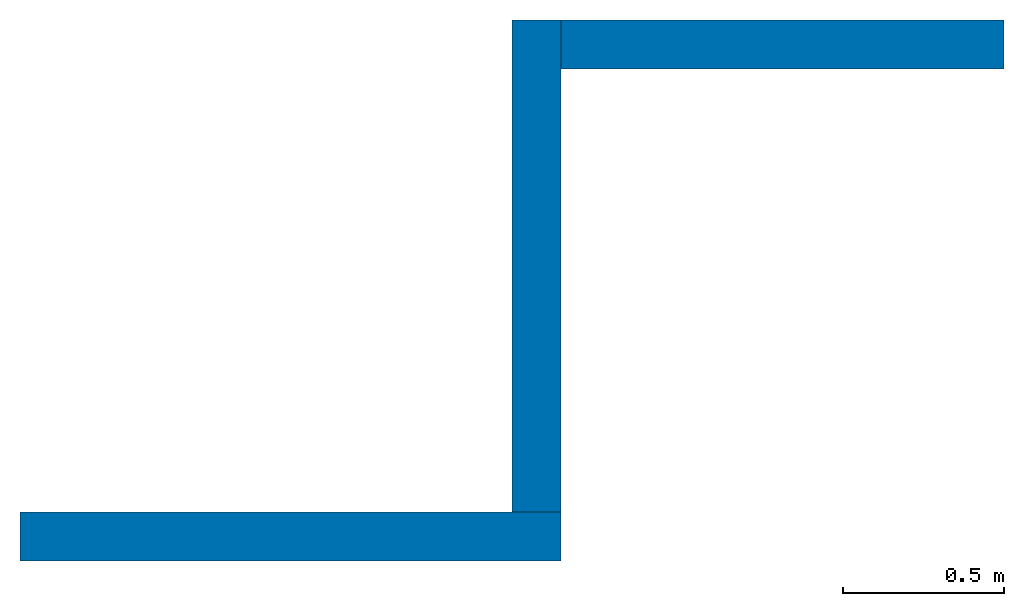
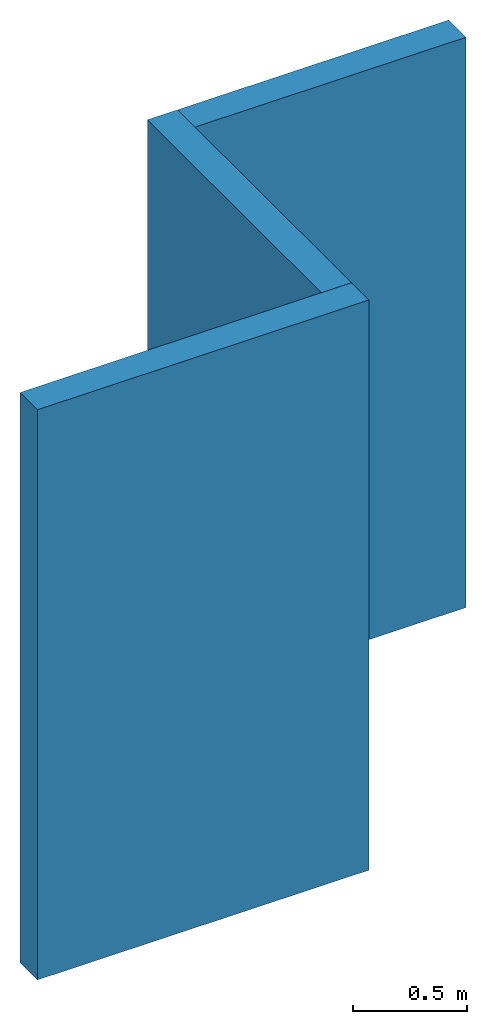
# One storey: 3 walls.
"""IFC2X3 building model written with IfcOpenShell, lengths in feet."""

import ifcopenshell
import ifcopenshell.guid

model = None  # the IFC model being written
_history = None  # IfcOwnerHistory: only IFC2X3 demands one
_inside = {}  # id of a spatial element -> (the spatial element, [elements in it])
_under = {}  # id of a project, library or spatial element -> (it, [spatial elements below it])
_declared = {}  # id of a project -> (the project, [libraries it declares])
_typed = {}  # id of a type object -> (the type object, [elements of that type])
_made_of = {}  # id of a material, layer set ... -> (it, [elements and type objects made of it])


def new_model(schema):
    """Start an empty IFC model of exactly this schema.

    Asked for "IFC4X3", IfcOpenShell would pick the latest addendum, in which some entities
    have other attributes; the version numbers below select the first issue.
    IFC2X3 requires an IfcOwnerHistory on every rooted entity: one is made here for all.
    """
    global model, _history
    if schema == "IFC4X3":
        model = ifcopenshell.file(schema_version=(4, 3, 0, 0))
    else:
        model = ifcopenshell.file(schema=schema)
    _inside.clear()
    _under.clear()
    _declared.clear()
    _typed.clear()
    _made_of.clear()
    _history = None
    if model.schema == "IFC2X3":
        org = make("IfcOrganization", Name="unknown")
        user = make(
            "IfcPersonAndOrganization",
            ThePerson=make("IfcPerson", FamilyName="unknown"),
            TheOrganization=org,
        )
        app = make(
            "IfcApplication",
            ApplicationDeveloper=org,
            Version="unknown",
            ApplicationFullName="unknown",
            ApplicationIdentifier="unknown",
        )
        _history = make(
            "IfcOwnerHistory",
            OwningUser=user,
            OwningApplication=app,
            ChangeAction="ADDED",
            CreationDate=0,
        )
    return model


def make(cls, **values):
    """One entity of the class cls with the attributes given. An attribute that is None is left unset."""
    return model.create_entity(
        cls, **{name: value for name, value in values.items() if value is not None}
    )


def entity(cls, *values):
    """Any entity or typed value of the class cls, its attributes in the order of the schema. None: left unset."""
    e = model.create_entity(cls)
    for i, value in enumerate(values):
        if value is not None:
            e[i] = value
    return e


def rooted(cls, **values):
    """An entity with a GlobalId (a new one), such as an element, a storey or a relation."""
    return make(cls, GlobalId=ifcopenshell.guid.new(), OwnerHistory=_history, **values)


def si_unit(unit_type, name, prefix=None):
    """IfcSIUnit, for example si_unit("LENGTHUNIT", "METRE", prefix="MILLI")."""
    return make("IfcSIUnit", UnitType=unit_type, Prefix=prefix, Name=name)


def converted_unit(unit_type, name, factor, base, dimensions=None, offset=None):
    """IfcConversionBasedUnit, such as the inch: factor (a typed value) times the base unit."""
    return make(
        "IfcConversionBasedUnit"
        if offset is None
        else "IfcConversionBasedUnitWithOffset",
        ConversionOffset=offset,
        Dimensions=None
        if dimensions is None
        else entity("IfcDimensionalExponents", *dimensions),
        UnitType=unit_type,
        Name=name,
        ConversionFactor=make(
            "IfcMeasureWithUnit", ValueComponent=factor, UnitComponent=base
        ),
    )


def derived_unit(unit_type, elements):
    """IfcDerivedUnit: a product of units, each with its exponent."""
    return make(
        "IfcDerivedUnit",
        Elements=[
            make("IfcDerivedUnitElement", Unit=unit, Exponent=power)
            for unit, power in elements
        ],
        UnitType=unit_type,
    )


def assignment(units):
    """IfcUnitAssignment: the units of a project."""
    return None if units is None else make("IfcUnitAssignment", Units=units)


def point(xyz):
    """IfcCartesianPoint."""
    return None if xyz is None else make("IfcCartesianPoint", Coordinates=xyz)


def direction(xyz):
    """IfcDirection."""
    return None if xyz is None else make("IfcDirection", DirectionRatios=xyz)


def frame(location, z_axis=None, x_axis=None):
    """IfcAxis2Placement3D, a coordinate frame: its origin and axes. An axis left out is left unset."""
    return make(
        "IfcAxis2Placement3D",
        Location=point(location),
        Axis=direction(z_axis),
        RefDirection=direction(x_axis),
    )


def frame_2d(location, x_axis=None):
    """IfcAxis2Placement2D, a coordinate frame in the plane: its origin and x axis."""
    return make(
        "IfcAxis2Placement2D", Location=point(location), RefDirection=direction(x_axis)
    )


def origin():
    """The frame at (0, 0, 0) with its axes left unset."""
    return frame((0.0, 0.0, 0.0))


def place(relative_to, where):
    """IfcLocalPlacement: puts the frame where relative to a parent placement (None: the world)."""
    return make(
        "IfcLocalPlacement", PlacementRelTo=relative_to, RelativePlacement=where
    )


def context(
    kind, dimensions, precision=None, world=None, true_north=None, identifier=None
):
    """IfcGeometricRepresentationContext, for example the 3D "Model" context."""
    return make(
        "IfcGeometricRepresentationContext",
        ContextIdentifier=identifier,
        ContextType=kind,
        CoordinateSpaceDimension=dimensions,
        Precision=precision,
        WorldCoordinateSystem=world,
        TrueNorth=true_north,
    )


def subcontext(parent, identifier, kind, view, scale=None):
    """IfcGeometricRepresentationSubContext, for example "Body" below "Model"."""
    return make(
        "IfcGeometricRepresentationSubContext",
        ContextIdentifier=identifier,
        ContextType=kind,
        ParentContext=parent,
        TargetScale=scale,
        TargetView=view,
    )


def project(units=None, contexts=None):
    """IfcProject with its units and contexts."""
    return rooted(
        "IfcProject",
        Name="project",
        RepresentationContexts=contexts,
        UnitsInContext=assignment(units),
    )


def spatial(cls, under=None, at=None, **own):
    """A site, building, storey or space (cls), placed at a placement, below another one or the project."""
    s = rooted(cls, ObjectPlacement=at, **own)
    if under is not None:
        _under.setdefault(under.id(), (under, []))[1].append(s)
    return s


def profile(cls, at=None, kind="AREA", **sizes):
    """A parametric profile (cls). Its sizes go by their IFC names, for example OverallWidth=200.0."""
    return make(cls, ProfileType=kind, Position=at, **sizes)


def rectangle(**sizes):
    """IfcRectangleProfileDef."""
    return profile("IfcRectangleProfileDef", **sizes)


def extrude(swept, where, along, depth):
    """IfcExtrudedAreaSolid: the profile swept, set in the frame where, extruded along a direction by depth."""
    return make(
        "IfcExtrudedAreaSolid",
        SweptArea=swept,
        Position=where,
        ExtrudedDirection=direction(along),
        Depth=depth,
    )


def shape(context_of_items, identifier, shape_type, items):
    """IfcShapeRepresentation: the items that make up one representation, for example the "Body"."""
    return make(
        "IfcShapeRepresentation",
        ContextOfItems=context_of_items,
        RepresentationIdentifier=identifier,
        RepresentationType=shape_type,
        Items=items,
    )


def material(Name=None, Category=None):
    """IfcMaterial."""
    return make("IfcMaterial", Name=Name, Category=Category)


def layer(
    of_material, thickness, ventilated=None, Name=None, Category=None, Priority=None
):
    """IfcMaterialLayer: one layer of a wall or slab, of a material (None: an air gap)."""
    return make(
        "IfcMaterialLayer",
        Material=of_material,
        LayerThickness=thickness,
        IsVentilated=ventilated,
        Name=Name,
        Category=Category,
        Priority=Priority,
    )


def layer_set(layers, Name=None):
    """IfcMaterialLayerSet."""
    return make("IfcMaterialLayerSet", MaterialLayers=layers, LayerSetName=Name)


def layer_usage(for_layer_set, set_direction, sense, offset, extent=None):
    """IfcMaterialLayerSetUsage: how a layer set lies in its element."""
    return make(
        "IfcMaterialLayerSetUsage",
        ForLayerSet=for_layer_set,
        LayerSetDirection=set_direction,
        DirectionSense=sense,
        OffsetFromReferenceLine=offset,
        ReferenceExtent=extent,
    )


def made_of(thing, what):
    """Note that an element or type object is made of a material, layer set ...; save() writes the relation."""
    if what is not None:
        _made_of.setdefault(what.id(), (what, []))[1].append(thing)
    return thing


def type_object(cls, material=None, **own):
    """A type object (cls), such as IfcWallType, which elements share."""
    return made_of(rooted(cls, **own), material)


def element(
    cls,
    number,
    at=None,
    inside=None,
    cuts=None,
    type_object=None,
    material=None,
    context=None,
    identifier="Body",
    shape_type=None,
    held_by="IfcProductDefinitionShape",
    body=None,
    shapes=None,
    **own,
):
    """One element of the class cls, such as IfcWall. Its Tag is "e" and its number.

    at: its placement. inside: the storey or other place that contains it. cuts: it is an
    opening in that element (IfcRelVoidsElement). A single representation is given by context,
    identifier, shape_type and body (its items); several are given by shapes. held_by: the class
    of the entity that holds the representations. save() writes the other relations.
    """
    e = rooted(cls, Tag="e%d" % number, ObjectPlacement=at, **own)
    if body is not None:
        shapes = [shape(context, identifier, shape_type, body)]
    if shapes is not None:
        e.Representation = make(held_by, Representations=shapes)
    if inside is not None:
        _inside.setdefault(inside.id(), (inside, []))[1].append(e)
    if cuts is not None:
        rooted(
            "IfcRelVoidsElement", RelatingBuildingElement=cuts, RelatedOpeningElement=e
        )
    if type_object is not None:
        _typed.setdefault(type_object.id(), (type_object, []))[1].append(e)
    return made_of(e, material)


def aggregate(whole, parts):
    """IfcRelAggregates: a whole, such as a stair, and the parts it consists of."""
    return rooted("IfcRelAggregates", RelatingObject=whole, RelatedObjects=parts)


def save(model, path):
    """Write the relations noted so far, then the file.

    IfcRelAggregates (storeys below a building ...), IfcRelContainedInSpatialStructure (elements
    in a storey), IfcRelDefinesByType, IfcRelAssociatesMaterial and IfcRelDeclares: one each for
    every whole, place, type object, material and project.
    """
    for whole, parts in _under.values():
        aggregate(whole, parts)
    for where, things in _inside.values():
        rooted(
            "IfcRelContainedInSpatialStructure",
            RelatedElements=things,
            RelatingStructure=where,
        )
    for kind, things in _typed.values():
        rooted("IfcRelDefinesByType", RelatedObjects=things, RelatingType=kind)
    for what, things in _made_of.values():
        rooted("IfcRelAssociatesMaterial", RelatedObjects=things, RelatingMaterial=what)
    for by, libraries in _declared.values():
        rooted("IfcRelDeclares", RelatingContext=by, RelatedDefinitions=libraries)
    model.write(path)


model = new_model("IFC2X3")

# Units and contexts
model_context = context("Model", 3, precision=0.0001, world=origin(), true_north=direction((6.12303176911189e-17, 1.0)))
body_context = subcontext(model_context, "Body", "Model", "MODEL_VIEW")
ifc_project = project(units=[converted_unit("LENGTHUNIT", "FOOT", entity("IfcRatioMeasure", 0.3048), si_unit("LENGTHUNIT", "METRE"), dimensions=[1, 0, 0, 0, 0, 0, 0]), converted_unit("AREAUNIT", "SQUARE FOOT", entity("IfcRatioMeasure", 0.09290304), si_unit("AREAUNIT", "SQUARE_METRE"), dimensions=[2, 0, 0, 0, 0, 0, 0]), converted_unit("VOLUMEUNIT", "CUBIC FOOT", entity("IfcRatioMeasure", 0.028316846592), si_unit("VOLUMEUNIT", "CUBIC_METRE"), dimensions=[3, 0, 0, 0, 0, 0, 0]), converted_unit("PLANEANGLEUNIT", "DEGREE", entity("IfcRatioMeasure", 0.0174532925199433), si_unit("PLANEANGLEUNIT", "RADIAN"), dimensions=[0, 0, 0, 0, 0, 0, 0]), si_unit("MASSUNIT", "GRAM", prefix="KILO"), derived_unit("MASSDENSITYUNIT", [(si_unit("MASSUNIT", "GRAM", prefix="KILO"), 1), (si_unit("LENGTHUNIT", "METRE"), -3)]), si_unit("TIMEUNIT", "SECOND"), si_unit("FREQUENCYUNIT", "HERTZ"), si_unit("THERMODYNAMICTEMPERATUREUNIT", "DEGREE_CELSIUS"), derived_unit("THERMALTRANSMITTANCEUNIT", [(si_unit("MASSUNIT", "GRAM", prefix="KILO"), 1), (si_unit("THERMODYNAMICTEMPERATUREUNIT", "KELVIN"), -1), (si_unit("TIMEUNIT", "SECOND"), -3)]), derived_unit("VOLUMETRICFLOWRATEUNIT", [(si_unit("LENGTHUNIT", "METRE"), 3), (si_unit("TIMEUNIT", "SECOND"), -1)]), si_unit("ELECTRICCURRENTUNIT", "AMPERE"), si_unit("ELECTRICVOLTAGEUNIT", "VOLT"), si_unit("POWERUNIT", "WATT"), si_unit("FORCEUNIT", "NEWTON"), si_unit("ILLUMINANCEUNIT", "LUX"), si_unit("LUMINOUSFLUXUNIT", "LUMEN"), si_unit("LUMINOUSINTENSITYUNIT", "CANDELA"), derived_unit("USERDEFINED", [(si_unit("MASSUNIT", "GRAM", prefix="KILO"), -1), (si_unit("LENGTHUNIT", "METRE"), -2), (si_unit("TIMEUNIT", "SECOND"), 3), (si_unit("LUMINOUSFLUXUNIT", "LUMEN"), 1)]), derived_unit("LINEARVELOCITYUNIT", [(si_unit("LENGTHUNIT", "METRE"), 1), (si_unit("TIMEUNIT", "SECOND"), -1)]), si_unit("PRESSUREUNIT", "PASCAL"), derived_unit("USERDEFINED", [(si_unit("LENGTHUNIT", "METRE"), -2), (si_unit("MASSUNIT", "GRAM", prefix="KILO"), 1), (si_unit("TIMEUNIT", "SECOND"), -2)])], contexts=[model_context])

# Site, building, storey
site_placement = place(None, origin())
site = spatial("IfcSite", under=ifc_project, at=site_placement, CompositionType="ELEMENT")
building_placement = place(site_placement, origin())
building = spatial("IfcBuilding", under=site, at=building_placement, CompositionType="ELEMENT")
storey_placement = place(building_placement, origin())
storey = spatial("IfcBuildingStorey", under=building, at=storey_placement, Name="Level 1", CompositionType="ELEMENT", Elevation=0.0)

# Walls
ifc_material = material(Name="Wall Material")
ifc_layer = layer(ifc_material, 0.5)
ifc_layer_set = layer_set([ifc_layer], Name="Basic Wall:Wall Type")
ifc_layer_usage_1 = layer_usage(ifc_layer_set, "AXIS2", "NEGATIVE", 0.25)
wall_type = type_object("IfcWallType", Name="Basic Wall:Wall Type", PredefinedType="STANDARD", material=ifc_layer_set)
wall_1_placement = place(storey_placement, frame((0.0, -0.250000000000003, 0.0)))
element("IfcWallStandardCase", 1, at=wall_1_placement, inside=storey, type_object=wall_type, material=ifc_layer_usage_1, Name="Basic Wall:Wall Type", ObjectType="Basic Wall:Wall Type", context=body_context, shape_type="SweptSolid", body=[
    extrude(rectangle(XDim=5.5, YDim=0.5, at=frame_2d((2.75, -1.38777878078145e-17), x_axis=(-1.0, 0.0))), origin(), (0.0, 0.0, 1.0), 10.0),
])
ifc_layer_usage_2 = layer_usage(ifc_layer_set, "AXIS2", "NEGATIVE", 0.25)
wall_2_placement = place(storey_placement, frame((5.25, 0.0, 0.0), z_axis=(0.0, 0.0, 1.0), x_axis=(0.0, 1.0, 0.0)))
element("IfcWallStandardCase", 2, at=wall_2_placement, inside=storey, type_object=wall_type, material=ifc_layer_usage_2, Name="Basic Wall:Wall Type", ObjectType="Basic Wall:Wall Type", context=body_context, shape_type="SweptSolid", body=[
    extrude(rectangle(XDim=5.0, YDim=0.5, at=frame_2d((2.5, 0.0), x_axis=(-1.0, 0.0))), origin(), (0.0, 0.0, 1.0), 10.0),
])
ifc_layer_usage_3 = layer_usage(ifc_layer_set, "AXIS2", "NEGATIVE", 0.25)
wall_3_placement = place(storey_placement, frame((5.50000000000002, 4.74999999999998, 0.0)))
element("IfcWallStandardCase", 3, at=wall_3_placement, inside=storey, type_object=wall_type, material=ifc_layer_usage_3, Name="Basic Wall:Wall Type", ObjectType="Basic Wall:Wall Type", context=body_context, shape_type="SweptSolid", body=[
    extrude(rectangle(XDim=4.5, YDim=0.5, at=frame_2d((2.25, 0.0), x_axis=(-1.0, 0.0))), origin(), (0.0, 0.0, 1.0), 10.0),
])

save(model, "model.ifc")
